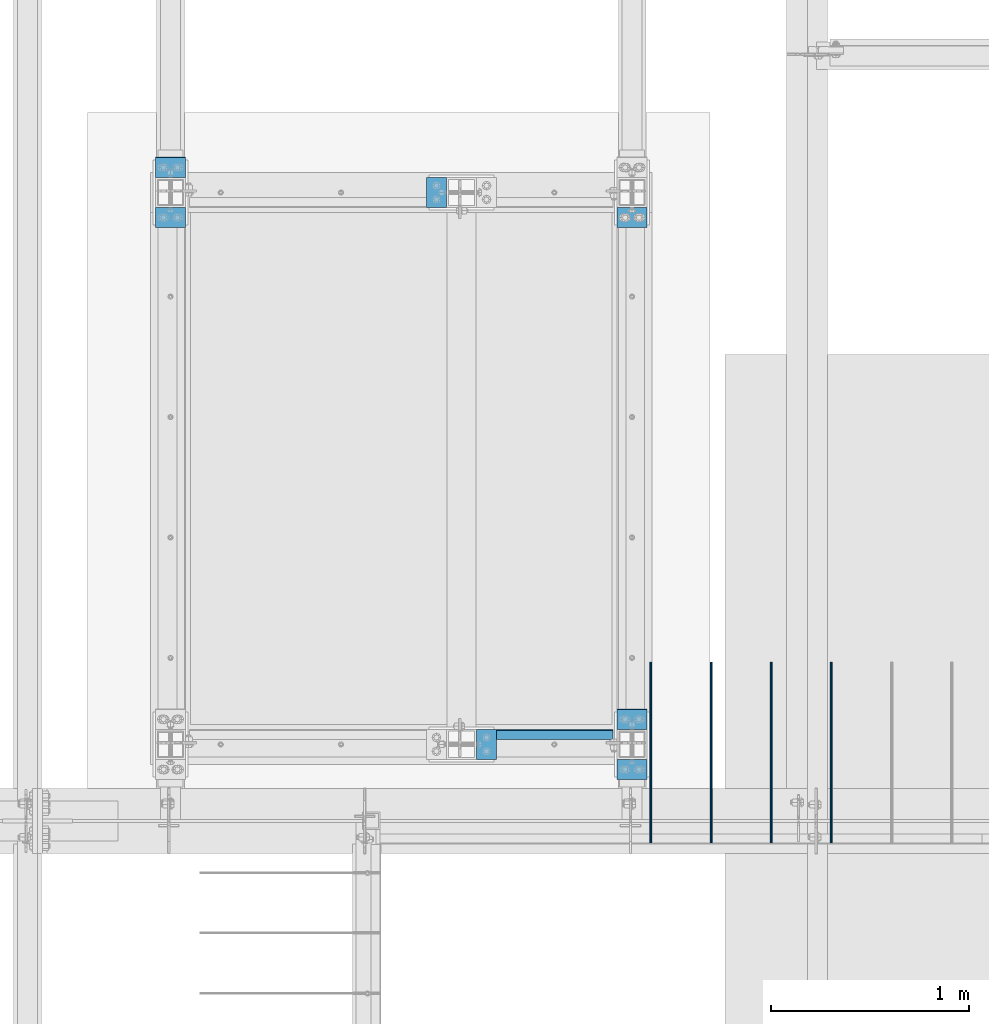
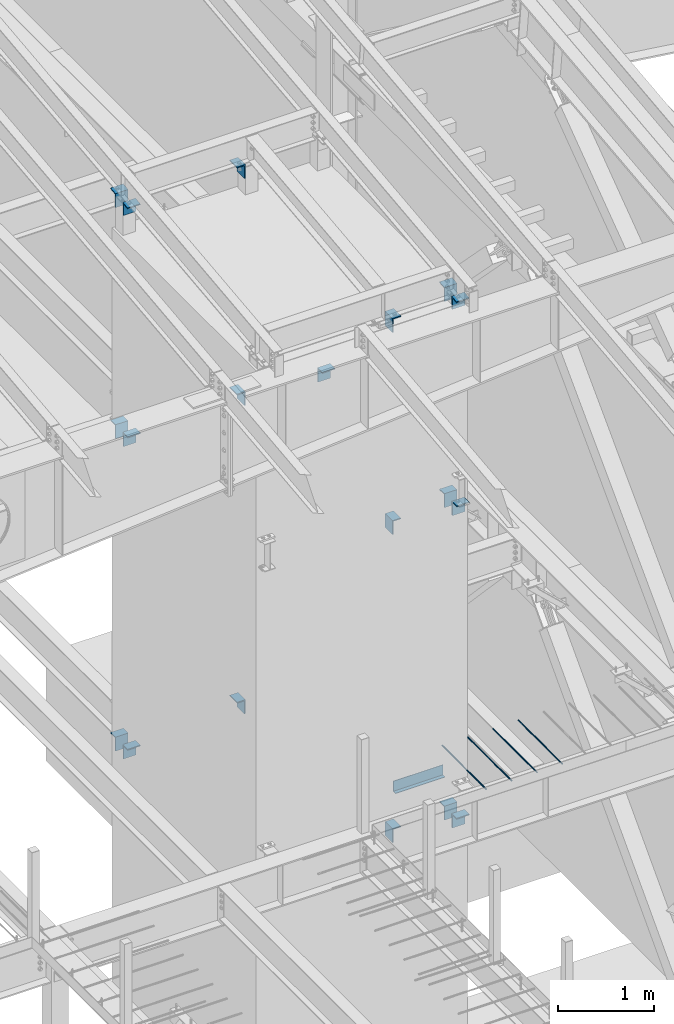
# One storey, part 824 of 1179: 24 beams, 18 elements without a shape of their own.
"""IFC2X3 building model written with IfcOpenShell, lengths in millimetres."""

from ifc_helpers import new_model, si_unit, frame, origin_with_axes, place, context, subcontext, project, spatial, faceted_brep, material, type_object, element, aggregate, save


model = new_model("IFC2X3")

# Units and contexts
model_context = context("Model", 3, precision=1e-05, world=origin_with_axes())
body_context = subcontext(model_context, "Body", "Model", "MODEL_VIEW")
ifc_project = project(units=[si_unit("LENGTHUNIT", "METRE", prefix="MILLI"), si_unit("AREAUNIT", "SQUARE_METRE"), si_unit("VOLUMEUNIT", "CUBIC_METRE"), si_unit("MASSUNIT", "GRAM", prefix="KILO"), si_unit("TIMEUNIT", "SECOND"), si_unit("PLANEANGLEUNIT", "RADIAN"), si_unit("SOLIDANGLEUNIT", "STERADIAN"), si_unit("THERMODYNAMICTEMPERATUREUNIT", "DEGREE_CELSIUS"), si_unit("LUMINOUSINTENSITYUNIT", "LUMEN")], contexts=[model_context])

# Site, building, storey
site_placement = place(None, origin_with_axes())
site = spatial("IfcSite", under=ifc_project, at=site_placement, CompositionType="ELEMENT")
building_placement = place(site_placement, origin_with_axes())
building = spatial("IfcBuilding", under=site, at=building_placement, Name="Undefined", CompositionType="ELEMENT")
storey_placement = place(building_placement, origin_with_axes())
storey = spatial("IfcBuildingStorey", under=building, at=storey_placement, Name="Undefined", CompositionType="ELEMENT", Elevation=0.0)

# Assembly, beam
assembly_1_placement = place(storey_placement, origin_with_axes())
assembly_1 = element("IfcElementAssembly", 1, at=assembly_1_placement, inside=storey, Name="BEAM", AssemblyPlace="NOTDEFINED", PredefinedType="RIGID_FRAME")
ifc_material_1 = material(Name="STEEL/A36")
beam_type_1 = type_object("IfcBeamType", PredefinedType="NOTDEFINED")
beam_1_placement = place(assembly_1_placement, frame((21082.0, 11941.1750007629, 4235.45000610352), z_axis=(1.0, 0.0, 0.0), x_axis=(0.0, 0.0, -1.0)))
beam_1 = element("IfcBeam", 2, at=beam_1_placement, type_object=beam_type_1, material=ifc_material_1, Name="BENT_PLATE", context=body_context, shape_type="Brep", body=[
    faceted_brep([(0.0, -3.17499999999927, -298.450000000001), (0.0, -3.17499999999927, 298.450000000001), (0.0, 3.17499999999927, 298.450000000001), (0.0, 3.17499999999927, -298.450000000001), (133.350006103517, 3.17499999999927, 298.450000000001), (133.350006103517, 3.17499999999927, -298.450000000001), (127.000006103516, -3.17499999999927, -298.450000000001), (127.000006103516, -3.17499999999927, 298.450000000001), (133.350006103517, -47.6250007629387, 298.450000000001), (133.350006103517, -47.6250007629387, -298.450000000001), (127.000006103516, -47.6250007629387, 298.450000000001), (127.000006103516, -47.6250007629387, -298.450000000001)], [[[0, 1, 2, 3]], [[3, 2, 4, 5]], [[1, 0, 6, 7]], [[5, 4, 8, 9]], [[4, 2, 1, 7, 10, 8]], [[7, 6, 11, 10]], [[6, 0, 3, 5, 9, 11]], [[10, 11, 9, 8]]]),
])
aggregate(assembly_1, [beam_1])

# Assembly, beams
assembly_2_placement = place(storey_placement, origin_with_axes())
assembly_2 = element("IfcElementAssembly", 3, at=assembly_2_placement, inside=storey, Name="COLUMN", AssemblyPlace="NOTDEFINED", PredefinedType="RIGID_FRAME")
beam_type_2 = type_object("IfcBeamType", PredefinedType="NOTDEFINED")
beam_2_placement = place(assembly_2_placement, frame((19138.8965677871, 14839.9499984852, 3692.52499649476), z_axis=(1.0, 0.0, 0.0), x_axis=(0.0, -1.0, 0.0)))
beam_2 = element("IfcBeam", 4, at=beam_2_placement, type_object=beam_type_2, material=ifc_material_1, Name="BENT_PLATE", context=body_context, shape_type="Brep", body=[
    faceted_brep([(7.27595761418343e-12, -6.35000000000036, -76.1999999999971), (0.0, -6.35000000000036, 76.2000000000044), (0.0, 6.35000000000036, 76.2000000000044), (-7.27595761418343e-12, 6.35000000000036, -76.1999999999971), (88.8999984741222, 6.34999999999991, 76.2000000000007), (88.8999984741222, 6.34999999999991, -76.2000000000007), (101.599998474123, -6.34999999999991, -76.2000000000007), (101.599998474123, -6.34999999999991, 76.2000000000007), (88.8999984741222, 171.450003051757, 76.2000000000007), (88.8999984741222, 171.450003051757, -76.2000000000007), (101.599998474123, 171.450003051757, 76.2000000000007), (101.599998474123, 171.450003051757, -76.2000000000007)], [[[0, 1, 2, 3]], [[3, 2, 4, 5]], [[1, 0, 6, 7]], [[5, 4, 8, 9]], [[4, 2, 1, 7, 10, 8]], [[7, 6, 11, 10]], [[6, 0, 3, 5, 9, 11]], [[10, 11, 9, 8]]]),
])
beam_3_placement = place(assembly_2_placement, frame((19138.8965677871, 14484.350001537, 3692.52499649476), z_axis=(1.0, 0.0, 0.0), x_axis=(0.0, 1.0, 0.0)))
beam_3 = element("IfcBeam", 5, at=beam_3_placement, type_object=beam_type_2, material=ifc_material_1, Name="BENT_PLATE", context=body_context, shape_type="Brep", body=[
    faceted_brep([(7.27595761418343e-12, -6.35000000000036, -76.1999999999971), (0.0, -6.35000000000036, 76.2000000000044), (0.0, 6.35000000000036, 76.2000000000044), (-7.27595761418343e-12, 6.35000000000036, -76.1999999999971), (101.599998474123, 6.34999999999991, 76.2000000000007), (101.599998474123, 6.34999999999991, -76.2000000000007), (88.8999984741222, -6.34999999999991, -76.2000000000007), (88.8999984741222, -6.34999999999991, 76.2000000000007), (101.599998474123, -171.450003051757, 76.2000000000007), (101.599998474123, -171.450003051757, -76.2000000000007), (88.8999984741222, -171.450003051757, 76.2000000000007), (88.8999984741222, -171.450003051757, -76.2000000000007)], [[[0, 1, 2, 3]], [[3, 2, 4, 5]], [[1, 0, 6, 7]], [[5, 4, 8, 9]], [[4, 2, 1, 7, 10, 8]], [[7, 6, 11, 10]], [[6, 0, 3, 5, 9, 11]], [[10, 11, 9, 8]]]),
])
aggregate(assembly_2, [beam_2, beam_3])

assembly_3_placement = place(storey_placement, origin_with_axes())
assembly_3 = element("IfcElementAssembly", 6, at=assembly_3_placement, inside=storey, Name="COLUMN", AssemblyPlace="NOTDEFINED", PredefinedType="RIGID_FRAME")
beam_4_placement = place(assembly_3_placement, frame((21475.7, 12045.9499984741, 7658.1), z_axis=(1.0, 0.0, 0.0), x_axis=(0.0, -1.0, 0.0)))
beam_4 = element("IfcBeam", 7, at=beam_4_placement, type_object=beam_type_2, material=ifc_material_1, Name="BENT_PLATE", context=body_context, shape_type="Brep", body=[
    faceted_brep([(7.27595761418343e-12, -6.35000000000036, -76.1999999999971), (0.0, -6.35000000000036, 76.2000000000044), (0.0, 6.35000000000036, 76.2000000000044), (-7.27595761418343e-12, 6.35000000000036, -76.1999999999971), (88.8999984741222, 6.34999999999991, 76.2000000000007), (88.8999984741222, 6.34999999999991, -76.2000000000007), (101.599998474123, -6.34999999999991, -76.2000000000007), (101.599998474123, -6.34999999999991, 76.2000000000007), (88.8999984741222, 171.450003051757, 76.2000000000007), (88.8999984741222, 171.450003051757, -76.2000000000007), (101.599998474123, 171.450003051757, 76.2000000000007), (101.599998474123, 171.450003051757, -76.2000000000007)], [[[0, 1, 2, 3]], [[3, 2, 4, 5]], [[1, 0, 6, 7]], [[5, 4, 8, 9]], [[4, 2, 1, 7, 10, 8]], [[7, 6, 11, 10]], [[6, 0, 3, 5, 9, 11]], [[10, 11, 9, 8]]]),
])
beam_5_placement = place(assembly_3_placement, frame((21475.7, 11690.3500015259, 7658.1), z_axis=(1.0, 0.0, 0.0), x_axis=(0.0, 1.0, 0.0)))
beam_5 = element("IfcBeam", 8, at=beam_5_placement, type_object=beam_type_2, material=ifc_material_1, Name="BENT_PLATE", context=body_context, shape_type="Brep", body=[
    faceted_brep([(7.27595761418343e-12, -6.35000000000036, -76.1999999999971), (0.0, -6.35000000000036, 76.2000000000044), (0.0, 6.35000000000036, 76.2000000000044), (-7.27595761418343e-12, 6.35000000000036, -76.1999999999971), (101.599998474123, 6.34999999999991, 76.2000000000007), (101.599998474123, 6.34999999999991, -76.2000000000007), (88.8999984741222, -6.34999999999991, -76.2000000000007), (88.8999984741222, -6.34999999999991, 76.2000000000007), (101.599998474123, -171.450003051757, 76.2000000000007), (101.599998474123, -171.450003051757, -76.2000000000007), (88.8999984741222, -171.450003051757, 76.2000000000007), (88.8999984741222, -171.450003051757, -76.2000000000007)], [[[0, 1, 2, 3]], [[3, 2, 4, 5]], [[1, 0, 6, 7]], [[5, 4, 8, 9]], [[4, 2, 1, 7, 10, 8]], [[7, 6, 11, 10]], [[6, 0, 3, 5, 9, 11]], [[10, 11, 9, 8]]]),
])
aggregate(assembly_3, [beam_4, beam_5])

assembly_4_placement = place(storey_placement, origin_with_axes())
assembly_4 = element("IfcElementAssembly", 9, at=assembly_4_placement, inside=storey, Name="COLUMN", AssemblyPlace="NOTDEFINED", PredefinedType="RIGID_FRAME")
beam_6_placement = place(assembly_4_placement, frame((19138.9, 14839.9499984741, 7658.1), z_axis=(1.0, 0.0, 0.0), x_axis=(0.0, -1.0, 0.0)))
beam_6 = element("IfcBeam", 10, at=beam_6_placement, type_object=beam_type_2, material=ifc_material_1, Name="BENT_PLATE", context=body_context, shape_type="Brep", body=[
    faceted_brep([(7.27595761418343e-12, -6.35000000000036, -76.1999999999971), (0.0, -6.35000000000036, 76.2000000000044), (0.0, 6.35000000000036, 76.2000000000044), (-7.27595761418343e-12, 6.35000000000036, -76.1999999999971), (88.8999984741222, 6.34999999999991, 76.2000000000007), (88.8999984741222, 6.34999999999991, -76.2000000000007), (101.599998474123, -6.34999999999991, -76.2000000000007), (101.599998474123, -6.34999999999991, 76.2000000000007), (88.8999984741222, 171.450003051757, 76.2000000000007), (88.8999984741222, 171.450003051757, -76.2000000000007), (101.599998474123, 171.450003051757, 76.2000000000007), (101.599998474123, 171.450003051757, -76.2000000000007)], [[[0, 1, 2, 3]], [[3, 2, 4, 5]], [[1, 0, 6, 7]], [[5, 4, 8, 9]], [[4, 2, 1, 7, 10, 8]], [[7, 6, 11, 10]], [[6, 0, 3, 5, 9, 11]], [[10, 11, 9, 8]]]),
])
beam_7_placement = place(assembly_4_placement, frame((19138.9, 14484.3500015259, 7658.1), z_axis=(1.0, 0.0, 0.0), x_axis=(0.0, 1.0, 0.0)))
beam_7 = element("IfcBeam", 11, at=beam_7_placement, type_object=beam_type_2, material=ifc_material_1, Name="BENT_PLATE", context=body_context, shape_type="Brep", body=[
    faceted_brep([(7.27595761418343e-12, -6.35000000000036, -76.1999999999971), (0.0, -6.35000000000036, 76.2000000000044), (0.0, 6.35000000000036, 76.2000000000044), (-7.27595761418343e-12, 6.35000000000036, -76.1999999999971), (101.599998474123, 6.34999999999991, 76.2000000000007), (101.599998474123, 6.34999999999991, -76.2000000000007), (88.8999984741222, -6.34999999999991, -76.2000000000007), (88.8999984741222, -6.34999999999991, 76.2000000000007), (101.599998474123, -171.450003051757, 76.2000000000007), (101.599998474123, -171.450003051757, -76.2000000000007), (88.8999984741222, -171.450003051757, 76.2000000000007), (88.8999984741222, -171.450003051757, -76.2000000000007)], [[[0, 1, 2, 3]], [[3, 2, 4, 5]], [[1, 0, 6, 7]], [[5, 4, 8, 9]], [[4, 2, 1, 7, 10, 8]], [[7, 6, 11, 10]], [[6, 0, 3, 5, 9, 11]], [[10, 11, 9, 8]]]),
])
aggregate(assembly_4, [beam_6, beam_7])

# Assembly, beam
assembly_5_placement = place(storey_placement, origin_with_axes())
assembly_5 = element("IfcElementAssembly", 12, at=assembly_5_placement, inside=storey, Name="COLUMN", AssemblyPlace="NOTDEFINED", PredefinedType="RIGID_FRAME")
beam_8_placement = place(assembly_5_placement, frame((21475.7, 14484.3500015259, 7658.1), z_axis=(1.0, 0.0, 0.0), x_axis=(0.0, 1.0, 0.0)))
beam_8 = element("IfcBeam", 13, at=beam_8_placement, type_object=beam_type_2, material=ifc_material_1, Name="BENT_PLATE", context=body_context, shape_type="Brep", body=[
    faceted_brep([(7.27595761418343e-12, -6.35000000000036, -76.1999999999971), (0.0, -6.35000000000036, 76.2000000000044), (0.0, 6.35000000000036, 76.2000000000044), (-7.27595761418343e-12, 6.35000000000036, -76.1999999999971), (101.599998474123, 6.34999999999991, 76.2000000000007), (101.599998474123, 6.34999999999991, -76.2000000000007), (88.8999984741222, -6.34999999999991, -76.2000000000007), (88.8999984741222, -6.34999999999991, 76.2000000000007), (101.599998474123, -171.450003051757, 76.2000000000007), (101.599998474123, -171.450003051757, -76.2000000000007), (88.8999984741222, -171.450003051757, 76.2000000000007), (88.8999984741222, -171.450003051757, -76.2000000000007)], [[[0, 1, 2, 3]], [[3, 2, 4, 5]], [[1, 0, 6, 7]], [[5, 4, 8, 9]], [[4, 2, 1, 7, 10, 8]], [[7, 6, 11, 10]], [[6, 0, 3, 5, 9, 11]], [[10, 11, 9, 8]]]),
])
aggregate(assembly_5, [beam_8])

assembly_6_placement = place(storey_placement, origin_with_axes())
assembly_6 = element("IfcElementAssembly", 14, at=assembly_6_placement, inside=storey, Name="COLUMN", AssemblyPlace="NOTDEFINED", PredefinedType="RIGID_FRAME")
beam_9_placement = place(assembly_6_placement, frame((20789.8999984741, 11868.15, 7658.1), z_axis=(0.0, 1.0, 0.0), x_axis=(-1.0, 0.0, 0.0)))
beam_9 = element("IfcBeam", 15, at=beam_9_placement, type_object=beam_type_2, material=ifc_material_1, Name="BENT_PLATE", context=body_context, shape_type="Brep", body=[
    faceted_brep([(7.27595761418343e-12, -6.35000000000036, -76.1999999999971), (0.0, -6.35000000000036, 76.2000000000044), (0.0, 6.35000000000036, 76.2000000000044), (-7.27595761418343e-12, 6.35000000000036, -76.1999999999971), (101.599998474123, 6.34999999999991, 76.2000000000007), (101.599998474123, 6.34999999999991, -76.2000000000007), (88.8999984741222, -6.34999999999991, -76.2000000000007), (88.8999984741222, -6.34999999999991, 76.2000000000007), (101.599998474123, -171.450003051757, 76.2000000000007), (101.599998474123, -171.450003051757, -76.2000000000007), (88.8999984741222, -171.450003051757, 76.2000000000007), (88.8999984741222, -171.450003051757, -76.2000000000007)], [[[0, 1, 2, 3]], [[3, 2, 4, 5]], [[1, 0, 6, 7]], [[5, 4, 8, 9]], [[4, 2, 1, 7, 10, 8]], [[7, 6, 11, 10]], [[6, 0, 3, 5, 9, 11]], [[10, 11, 9, 8]]]),
])
aggregate(assembly_6, [beam_9])

assembly_7_placement = place(storey_placement, origin_with_axes())
assembly_7 = element("IfcElementAssembly", 16, at=assembly_7_placement, inside=storey, Name="COLUMN", AssemblyPlace="NOTDEFINED", PredefinedType="RIGID_FRAME")
beam_10_placement = place(assembly_7_placement, frame((20434.3000015259, 14662.15, 7658.1), z_axis=(0.0, 1.0, 0.0), x_axis=(1.0, 0.0, 0.0)))
beam_10 = element("IfcBeam", 17, at=beam_10_placement, type_object=beam_type_2, material=ifc_material_1, Name="BENT_PLATE", context=body_context, shape_type="Brep", body=[
    faceted_brep([(7.27595761418343e-12, -6.35000000000036, -76.1999999999971), (0.0, -6.35000000000036, 76.2000000000044), (0.0, 6.35000000000036, 76.2000000000044), (-7.27595761418343e-12, 6.35000000000036, -76.1999999999971), (88.8999984741222, 6.34999999999991, 76.2000000000007), (88.8999984741222, 6.34999999999991, -76.2000000000007), (101.599998474123, -6.34999999999991, -76.2000000000007), (101.599998474123, -6.34999999999991, 76.2000000000007), (88.8999984741222, 171.450003051757, 76.2000000000007), (88.8999984741222, 171.450003051757, -76.2000000000007), (101.599998474123, 171.450003051757, 76.2000000000007), (101.599998474123, 171.450003051757, -76.2000000000007)], [[[0, 1, 2, 3]], [[3, 2, 4, 5]], [[1, 0, 6, 7]], [[5, 4, 8, 9]], [[4, 2, 1, 7, 10, 8]], [[7, 6, 11, 10]], [[6, 0, 3, 5, 9, 11]], [[10, 11, 9, 8]]]),
])
aggregate(assembly_7, [beam_10])

# Assembly, beams
assembly_8_placement = place(storey_placement, origin_with_axes())
assembly_8 = element("IfcElementAssembly", 18, at=assembly_8_placement, inside=storey, Name="COLUMN", AssemblyPlace="NOTDEFINED", PredefinedType="RIGID_FRAME")
beam_11_placement = place(assembly_8_placement, frame((21475.7, 12046.6686266753, 10288.708863098), z_axis=(1.0, 0.0, 0.0), x_axis=(2.37931089941412e-10, -0.993575662698832, -0.113169794965695)))
beam_11 = element("IfcBeam", 19, at=beam_11_placement, type_object=beam_type_2, material=ifc_material_1, Name="BENT_PLATE", context=body_context, shape_type="Brep", body=[
    faceted_brep([(7.27595761418343e-12, -6.35000000000036, -76.1999999999971), (0.0, -6.35000000000036, 76.2000000000044), (0.0, 6.35000000000036, 76.2000000000044), (-7.27595761418343e-12, 6.35000000000036, -76.1999999999971), (90.9468588647287, 6.35000004562426, 76.2000000000007), (90.9468588647287, 6.35000004562426, -76.2000000000007), (102.284159680639, -6.34999994868303, -76.2000000000007), (102.284159680639, -6.34999994868303, 76.2000000000007), (109.787335175104, 171.984030604186, 76.2000000000007), (109.787335175104, 171.984030604186, -76.2000000000007), (122.405964338148, 170.548691604019, 76.2000000000007), (122.405964338148, 170.548691604019, -76.2000000000007)], [[[0, 1, 2, 3]], [[3, 2, 4, 5]], [[1, 0, 6, 7]], [[5, 4, 8, 9]], [[4, 2, 1, 7, 10, 8]], [[7, 6, 11, 10]], [[6, 0, 3, 5, 9, 11]], [[10, 11, 9, 8]]]),
])
beam_12_placement = place(assembly_8_placement, frame((21475.7, 11691.7055089898, 10248.5067435805), z_axis=(1.0, 0.0, 0.0), x_axis=(0.0, 0.993676146336441, 0.112284087038017)))
beam_12 = element("IfcBeam", 20, at=beam_12_placement, type_object=beam_type_2, material=ifc_material_1, Name="BENT_PLATE", context=body_context, shape_type="Brep", body=[
    faceted_brep([(7.27595761418343e-12, -6.35000000000036, -76.1999999999971), (0.0, -6.35000000000036, 76.2000000000044), (0.0, 6.35000000000036, 76.2000000000044), (-7.27595761418343e-12, 6.35000000000036, -76.1999999999971), (101.599998474123, 6.34999999999991, 76.2000000000007), (101.599998474123, 6.34999999999991, -76.2000000000007), (87.3840912620235, -6.35000000880973, -76.2000000000007), (87.3840912620235, -6.35000000880973, 76.2000000000007), (83.5423060723097, -153.454462787842, 76.2000000000007), (83.5423060723097, -153.454462787842, -76.2000000000007), (70.9226190138452, -152.02845488246, 76.2000000000007), (70.9226190138452, -152.02845488246, -76.2000000000007)], [[[0, 1, 2, 3]], [[3, 2, 4, 5]], [[1, 0, 6, 7]], [[5, 4, 8, 9]], [[4, 2, 1, 7, 10, 8]], [[7, 6, 11, 10]], [[6, 0, 3, 5, 9, 11]], [[10, 11, 9, 8]]]),
])
aggregate(assembly_8, [beam_11, beam_12])

assembly_9_placement = place(storey_placement, origin_with_axes())
assembly_9 = element("IfcElementAssembly", 21, at=assembly_9_placement, inside=storey, Name="COLUMN", AssemblyPlace="NOTDEFINED", PredefinedType="RIGID_FRAME")
beam_13_placement = place(assembly_9_placement, frame((19138.9, 14840.6686266753, 10604.4271585818), z_axis=(1.0, 0.0, 0.0), x_axis=(2.37931089941412e-10, -0.993575662698832, -0.113169794965695)))
beam_13 = element("IfcBeam", 22, at=beam_13_placement, type_object=beam_type_2, material=ifc_material_1, Name="BENT_PLATE", context=body_context, shape_type="Brep", body=[
    faceted_brep([(7.27595761418343e-12, -6.35000000000036, -76.1999999999971), (0.0, -6.35000000000036, 76.2000000000044), (0.0, 6.35000000000036, 76.2000000000044), (-7.27595761418343e-12, 6.35000000000036, -76.1999999999971), (90.9468588647287, 6.35000004562426, 76.2000000000007), (90.9468588647287, 6.35000004562426, -76.2000000000007), (102.284159680639, -6.34999994868303, -76.2000000000007), (102.284159680639, -6.34999994868303, 76.2000000000007), (109.787335175104, 171.984030604186, 76.2000000000007), (109.787335175104, 171.984030604186, -76.2000000000007), (122.405964338148, 170.548691604019, 76.2000000000007), (122.405964338148, 170.548691604019, -76.2000000000007)], [[[0, 1, 2, 3]], [[3, 2, 4, 5]], [[1, 0, 6, 7]], [[5, 4, 8, 9]], [[4, 2, 1, 7, 10, 8]], [[7, 6, 11, 10]], [[6, 0, 3, 5, 9, 11]], [[10, 11, 9, 8]]]),
])
beam_14_placement = place(assembly_9_placement, frame((19138.9, 14485.7055089898, 10564.2250390642), z_axis=(1.0, 0.0, 0.0), x_axis=(0.0, 0.993676146336441, 0.112284087038017)))
beam_14 = element("IfcBeam", 23, at=beam_14_placement, type_object=beam_type_2, material=ifc_material_1, Name="BENT_PLATE", context=body_context, shape_type="Brep", body=[
    faceted_brep([(7.27595761418343e-12, -6.35000000000036, -76.1999999999971), (0.0, -6.35000000000036, 76.2000000000044), (0.0, 6.35000000000036, 76.2000000000044), (-7.27595761418343e-12, 6.35000000000036, -76.1999999999971), (101.599998474123, 6.34999999999991, 76.2000000000007), (101.599998474123, 6.34999999999991, -76.2000000000007), (87.3840912620235, -6.35000000880973, -76.2000000000007), (87.3840912620235, -6.35000000880973, 76.2000000000007), (83.5423060723097, -153.454462787842, 76.2000000000007), (83.5423060723097, -153.454462787842, -76.2000000000007), (70.9226190138452, -152.02845488246, 76.2000000000007), (70.9226190138452, -152.02845488246, -76.2000000000007)], [[[0, 1, 2, 3]], [[3, 2, 4, 5]], [[1, 0, 6, 7]], [[5, 4, 8, 9]], [[4, 2, 1, 7, 10, 8]], [[7, 6, 11, 10]], [[6, 0, 3, 5, 9, 11]], [[10, 11, 9, 8]]]),
])
aggregate(assembly_9, [beam_13, beam_14])

# Assembly, beam
assembly_10_placement = place(storey_placement, origin_with_axes())
assembly_10 = element("IfcElementAssembly", 24, at=assembly_10_placement, inside=storey, Name="COLUMN", AssemblyPlace="NOTDEFINED", PredefinedType="RIGID_FRAME")
beam_15_placement = place(assembly_10_placement, frame((20789.8999984741, 11868.15, 10225.285937), z_axis=(0.0, 1.0, 0.0), x_axis=(-1.0, 0.0, 0.0)))
beam_15 = element("IfcBeam", 25, at=beam_15_placement, type_object=beam_type_2, material=ifc_material_1, Name="BENT_PLATE", context=body_context, shape_type="Brep", body=[
    faceted_brep([(7.27595761418343e-12, -6.35000000000036, -76.1999999999971), (0.0, -6.35000000000036, 76.2000000000044), (0.0, 6.35000000000036, 76.2000000000044), (-7.27595761418343e-12, 6.35000000000036, -76.1999999999971), (101.599998474123, 6.34999999999991, 76.2000000000007), (101.599998474123, 6.34999999999991, -76.2000000000007), (88.8999984741222, -6.34999999999991, -76.2000000000007), (88.8999984741222, -6.34999999999991, 76.2000000000007), (101.599998474123, -171.450003051757, 76.2000000000007), (101.599998474123, -171.450003051757, -76.2000000000007), (88.8999984741222, -171.450003051757, 76.2000000000007), (88.8999984741222, -171.450003051757, -76.2000000000007)], [[[0, 1, 2, 3]], [[3, 2, 4, 5]], [[1, 0, 6, 7]], [[5, 4, 8, 9]], [[4, 2, 1, 7, 10, 8]], [[7, 6, 11, 10]], [[6, 0, 3, 5, 9, 11]], [[10, 11, 9, 8]]]),
])
aggregate(assembly_10, [beam_15])

assembly_11_placement = place(storey_placement, origin_with_axes())
assembly_11 = element("IfcElementAssembly", 26, at=assembly_11_placement, inside=storey, Name="COLUMN", AssemblyPlace="NOTDEFINED", PredefinedType="RIGID_FRAME")
beam_16_placement = place(assembly_11_placement, frame((20434.3000015259, 14662.15, 10540.9082183146), z_axis=(0.0, 1.0, 0.0), x_axis=(1.0, 0.0, 0.0)))
beam_16 = element("IfcBeam", 27, at=beam_16_placement, type_object=beam_type_2, material=ifc_material_1, Name="BENT_PLATE", context=body_context, shape_type="Brep", body=[
    faceted_brep([(7.27595761418343e-12, -6.35000000000036, -76.1999999999971), (0.0, -6.35000000000036, 76.2000000000044), (0.0, 6.35000000000036, 76.2000000000044), (-7.27595761418343e-12, 6.35000000000036, -76.1999999999971), (88.8999984741222, 6.34999999999991, 76.2000000000007), (88.8999984741222, 6.34999999999991, -76.2000000000007), (101.599998474123, -6.34999999999991, -76.2000000000007), (101.599998474123, -6.34999999999991, 76.2000000000007), (88.8999984741222, 171.450003051757, 76.2000000000007), (88.8999984741222, 171.450003051757, -76.2000000000007), (101.599998474123, 171.450003051757, 76.2000000000007), (101.599998474123, 171.450003051757, -76.2000000000007)], [[[0, 1, 2, 3]], [[3, 2, 4, 5]], [[1, 0, 6, 7]], [[5, 4, 8, 9]], [[4, 2, 1, 7, 10, 8]], [[7, 6, 11, 10]], [[6, 0, 3, 5, 9, 11]], [[10, 11, 9, 8]]]),
])
aggregate(assembly_11, [beam_16])

assembly_12_placement = place(storey_placement, origin_with_axes())
assembly_12 = element("IfcElementAssembly", 28, at=assembly_12_placement, inside=storey, Name="COLUMN", AssemblyPlace="NOTDEFINED", PredefinedType="RIGID_FRAME")
beam_17_placement = place(assembly_12_placement, frame((20789.8999984741, 11868.15, 3746.49999998571), z_axis=(0.0, 1.0, 0.0), x_axis=(-1.0, 0.0, 0.0)))
beam_17 = element("IfcBeam", 29, at=beam_17_placement, type_object=beam_type_2, material=ifc_material_1, Name="BENT_PLATE", context=body_context, shape_type="Brep", body=[
    faceted_brep([(7.27595761418343e-12, -6.35000000000036, -76.1999999999971), (0.0, -6.35000000000036, 76.2000000000044), (0.0, 6.35000000000036, 76.2000000000044), (-7.27595761418343e-12, 6.35000000000036, -76.1999999999971), (101.599998474123, 6.34999999999991, 76.2000000000007), (101.599998474123, 6.34999999999991, -76.2000000000007), (88.8999984741222, -6.34999999999991, -76.2000000000007), (88.8999984741222, -6.34999999999991, 76.2000000000007), (101.599998474123, -171.450003051757, 76.2000000000007), (101.599998474123, -171.450003051757, -76.2000000000007), (88.8999984741222, -171.450003051757, 76.2000000000007), (88.8999984741222, -171.450003051757, -76.2000000000007)], [[[0, 1, 2, 3]], [[3, 2, 4, 5]], [[1, 0, 6, 7]], [[5, 4, 8, 9]], [[4, 2, 1, 7, 10, 8]], [[7, 6, 11, 10]], [[6, 0, 3, 5, 9, 11]], [[10, 11, 9, 8]]]),
])
aggregate(assembly_12, [beam_17])

assembly_13_placement = place(storey_placement, origin_with_axes())
assembly_13 = element("IfcElementAssembly", 30, at=assembly_13_placement, inside=storey, Name="COLUMN", AssemblyPlace="NOTDEFINED", PredefinedType="RIGID_FRAME")
beam_18_placement = place(assembly_13_placement, frame((20434.3000015259, 14662.15, 3746.5), z_axis=(0.0, 1.0, 0.0), x_axis=(1.0, 0.0, 0.0)))
beam_18 = element("IfcBeam", 31, at=beam_18_placement, type_object=beam_type_2, material=ifc_material_1, Name="BENT_PLATE", context=body_context, shape_type="Brep", body=[
    faceted_brep([(7.27595761418343e-12, -6.35000000000036, -76.1999999999971), (0.0, -6.35000000000036, 76.2000000000044), (0.0, 6.35000000000036, 76.2000000000044), (-7.27595761418343e-12, 6.35000000000036, -76.1999999999971), (88.8999984741222, 6.34999999999991, 76.2000000000007), (88.8999984741222, 6.34999999999991, -76.2000000000007), (101.599998474123, -6.34999999999991, -76.2000000000007), (101.599998474123, -6.34999999999991, 76.2000000000007), (88.8999984741222, 171.450003051757, 76.2000000000007), (88.8999984741222, 171.450003051757, -76.2000000000007), (101.599998474123, 171.450003051757, 76.2000000000007), (101.599998474123, 171.450003051757, -76.2000000000007)], [[[0, 1, 2, 3]], [[3, 2, 4, 5]], [[1, 0, 6, 7]], [[5, 4, 8, 9]], [[4, 2, 1, 7, 10, 8]], [[7, 6, 11, 10]], [[6, 0, 3, 5, 9, 11]], [[10, 11, 9, 8]]]),
])
aggregate(assembly_13, [beam_18])

# Assembly, beams
assembly_14_placement = place(storey_placement, origin_with_axes())
assembly_14 = element("IfcElementAssembly", 32, at=assembly_14_placement, inside=storey, Name="COLUMN", AssemblyPlace="NOTDEFINED", PredefinedType="RIGID_FRAME")
beam_19_placement = place(assembly_14_placement, frame((21475.6998279452, 12045.9499984741, 3692.52499649481), z_axis=(1.0, 0.0, 0.0), x_axis=(0.0, -1.0, 0.0)))
beam_19 = element("IfcBeam", 33, at=beam_19_placement, type_object=beam_type_2, material=ifc_material_1, Name="BENT_PLATE", context=body_context, shape_type="Brep", body=[
    faceted_brep([(7.27595761418343e-12, -6.35000000000036, -76.1999999999971), (0.0, -6.35000000000036, 76.2000000000044), (0.0, 6.35000000000036, 76.2000000000044), (-7.27595761418343e-12, 6.35000000000036, -76.1999999999971), (88.8999984741222, 6.34999999999991, 76.2000000000007), (88.8999984741222, 6.34999999999991, -76.2000000000007), (101.599998474123, -6.34999999999991, -76.2000000000007), (101.599998474123, -6.34999999999991, 76.2000000000007), (88.8999984741222, 171.450003051757, 76.2000000000007), (88.8999984741222, 171.450003051757, -76.2000000000007), (101.599998474123, 171.450003051757, 76.2000000000007), (101.599998474123, 171.450003051757, -76.2000000000007)], [[[0, 1, 2, 3]], [[3, 2, 4, 5]], [[1, 0, 6, 7]], [[5, 4, 8, 9]], [[4, 2, 1, 7, 10, 8]], [[7, 6, 11, 10]], [[6, 0, 3, 5, 9, 11]], [[10, 11, 9, 8]]]),
])
beam_20_placement = place(assembly_14_placement, frame((21475.6998284746, 11690.3500015259, 3692.52499649481), z_axis=(1.0, 0.0, 0.0), x_axis=(0.0, 1.0, 0.0)))
beam_20 = element("IfcBeam", 34, at=beam_20_placement, type_object=beam_type_2, material=ifc_material_1, Name="BENT_PLATE", context=body_context, shape_type="Brep", body=[
    faceted_brep([(7.27595761418343e-12, -6.35000000000036, -76.1999999999971), (0.0, -6.35000000000036, 76.2000000000044), (0.0, 6.35000000000036, 76.2000000000044), (-7.27595761418343e-12, 6.35000000000036, -76.1999999999971), (101.599998474123, 6.34999999999991, 76.2000000000007), (101.599998474123, 6.34999999999991, -76.2000000000007), (88.8999984741222, -6.34999999999991, -76.2000000000007), (88.8999984741222, -6.34999999999991, 76.2000000000007), (101.599998474123, -171.450003051757, 76.2000000000007), (101.599998474123, -171.450003051757, -76.2000000000007), (88.8999984741222, -171.450003051757, 76.2000000000007), (88.8999984741222, -171.450003051757, -76.2000000000007)], [[[0, 1, 2, 3]], [[3, 2, 4, 5]], [[1, 0, 6, 7]], [[5, 4, 8, 9]], [[4, 2, 1, 7, 10, 8]], [[7, 6, 11, 10]], [[6, 0, 3, 5, 9, 11]], [[10, 11, 9, 8]]]),
])
aggregate(assembly_14, [beam_19, beam_20])

# Assembly, beam
assembly_15_placement = place(storey_placement, origin_with_axes())
assembly_15 = element("IfcElementAssembly", 35, at=assembly_15_placement, inside=storey, Name="#4 DOWEL", AssemblyPlace="NOTDEFINED", PredefinedType="NOTDEFINED")
ifc_material_2 = material(Name="REBAR/A615-40")
beam_type_3 = type_object("IfcBeamType", Name="#4 DOWEL", PredefinedType="NOTDEFINED")
beam_21_placement = place(assembly_15_placement, frame((22485.35, 11369.675, 4203.70000610352), z_axis=(0.0, 0.0, 1.0), x_axis=(0.0, 1.0, 0.0)))
beam_21 = element("IfcBeam", 36, at=beam_21_placement, type_object=beam_type_3, material=ifc_material_2, Name="#4 DOWEL", ObjectType="#4 DOWEL", context=body_context, shape_type="Brep", body=[
    faceted_brep([(0.0, -6.34999999999854, 0.0), (0.0, -4.49012806053361, -4.49012806053452), (914.399999999994, -4.49012806053452, -4.49012806042992), (914.399999999994, -6.34999999999991, 1.0550138540566e-10), (0.0, 0.0, -6.34999999999991), (914.399999999994, 0.0, -6.34999999989668), (0.0, 4.49012806053361, -4.49012806053452), (914.399999999994, 4.49012806053452, -4.49012806042992), (0.0, 6.34999999999854, 0.0), (914.399999999994, 6.34999999999991, 1.0550138540566e-10), (0.0, 4.49012806053361, 4.49012806053452), (914.399999999995, 4.49012806053452, 4.49012806064184), (0.0, 0.0, 6.34999999999991), (914.399999999995, 0.0, 6.35000000010768), (0.0, -4.49012806053361, 4.49012806053452), (914.399999999995, -4.49012806053452, 4.49012806064184)], [[[0, 1, 2, 3]], [[1, 4, 5, 2]], [[4, 6, 7, 5]], [[6, 8, 9, 7]], [[8, 10, 11, 9]], [[10, 12, 13, 11]], [[12, 14, 15, 13]], [[14, 0, 3, 15]], [[5, 7, 9, 11, 13, 15, 3, 2]], [[14, 12, 10, 8, 6, 4, 1, 0]]]),
])
aggregate(assembly_15, [beam_21])

assembly_16_placement = place(storey_placement, origin_with_axes())
assembly_16 = element("IfcElementAssembly", 37, at=assembly_16_placement, inside=storey, Name="#4 DOWEL", AssemblyPlace="NOTDEFINED", PredefinedType="NOTDEFINED")
beam_22_placement = place(assembly_16_placement, frame((22180.55, 11369.675, 4203.70000610352), z_axis=(0.0, 0.0, 1.0), x_axis=(0.0, 1.0, 0.0)))
beam_22 = element("IfcBeam", 38, at=beam_22_placement, type_object=beam_type_3, material=ifc_material_2, Name="#4 DOWEL", ObjectType="#4 DOWEL", context=body_context, shape_type="Brep", body=[
    faceted_brep([(0.0, -6.34999999999854, 0.0), (0.0, -4.49012806053361, -4.49012806053452), (914.399999999994, -4.49012806053452, -4.49012806042992), (914.399999999994, -6.34999999999991, 1.0550138540566e-10), (0.0, 0.0, -6.34999999999991), (914.399999999994, 0.0, -6.34999999989668), (0.0, 4.49012806053361, -4.49012806053452), (914.399999999994, 4.49012806053452, -4.49012806042992), (0.0, 6.34999999999854, 0.0), (914.399999999994, 6.34999999999991, 1.0550138540566e-10), (0.0, 4.49012806053361, 4.49012806053452), (914.399999999995, 4.49012806053452, 4.49012806064184), (0.0, 0.0, 6.34999999999991), (914.399999999995, 0.0, 6.35000000010768), (0.0, -4.49012806053361, 4.49012806053452), (914.399999999995, -4.49012806053452, 4.49012806064184)], [[[0, 1, 2, 3]], [[1, 4, 5, 2]], [[4, 6, 7, 5]], [[6, 8, 9, 7]], [[8, 10, 11, 9]], [[10, 12, 13, 11]], [[12, 14, 15, 13]], [[14, 0, 3, 15]], [[5, 7, 9, 11, 13, 15, 3, 2]], [[14, 12, 10, 8, 6, 4, 1, 0]]]),
])
aggregate(assembly_16, [beam_22])

assembly_17_placement = place(storey_placement, origin_with_axes())
assembly_17 = element("IfcElementAssembly", 39, at=assembly_17_placement, inside=storey, Name="#4 DOWEL", AssemblyPlace="NOTDEFINED", PredefinedType="NOTDEFINED")
beam_23_placement = place(assembly_17_placement, frame((21875.75, 11369.675, 4203.70000610352), z_axis=(0.0, 0.0, 1.0), x_axis=(0.0, 1.0, 0.0)))
beam_23 = element("IfcBeam", 40, at=beam_23_placement, type_object=beam_type_3, material=ifc_material_2, Name="#4 DOWEL", ObjectType="#4 DOWEL", context=body_context, shape_type="Brep", body=[
    faceted_brep([(0.0, -6.34999999999854, 0.0), (0.0, -4.49012806053361, -4.49012806053452), (914.399999999994, -4.49012806053452, -4.49012806042992), (914.399999999994, -6.34999999999991, 1.0550138540566e-10), (0.0, 0.0, -6.34999999999991), (914.399999999994, 0.0, -6.34999999989668), (0.0, 4.49012806053361, -4.49012806053452), (914.399999999994, 4.49012806053452, -4.49012806042992), (0.0, 6.34999999999854, 0.0), (914.399999999994, 6.34999999999991, 1.0550138540566e-10), (0.0, 4.49012806053361, 4.49012806053452), (914.399999999995, 4.49012806053452, 4.49012806064184), (0.0, 0.0, 6.34999999999991), (914.399999999995, 0.0, 6.35000000010768), (0.0, -4.49012806053361, 4.49012806053452), (914.399999999995, -4.49012806053452, 4.49012806064184)], [[[0, 1, 2, 3]], [[1, 4, 5, 2]], [[4, 6, 7, 5]], [[6, 8, 9, 7]], [[8, 10, 11, 9]], [[10, 12, 13, 11]], [[12, 14, 15, 13]], [[14, 0, 3, 15]], [[5, 7, 9, 11, 13, 15, 3, 2]], [[14, 12, 10, 8, 6, 4, 1, 0]]]),
])
aggregate(assembly_17, [beam_23])

assembly_18_placement = place(storey_placement, origin_with_axes())
assembly_18 = element("IfcElementAssembly", 41, at=assembly_18_placement, inside=storey, Name="#4 DOWEL", AssemblyPlace="NOTDEFINED", PredefinedType="NOTDEFINED")
beam_24_placement = place(assembly_18_placement, frame((21570.95, 11369.675, 4203.70000610352), z_axis=(0.0, 0.0, 1.0), x_axis=(0.0, 1.0, 0.0)))
beam_24 = element("IfcBeam", 42, at=beam_24_placement, type_object=beam_type_3, material=ifc_material_2, Name="#4 DOWEL", ObjectType="#4 DOWEL", context=body_context, shape_type="Brep", body=[
    faceted_brep([(0.0, -6.34999999999854, 0.0), (0.0, -4.49012806053361, -4.49012806053452), (914.399999999994, -4.49012806053452, -4.49012806042992), (914.399999999994, -6.34999999999991, 1.0550138540566e-10), (0.0, 0.0, -6.34999999999991), (914.399999999994, 0.0, -6.34999999989668), (0.0, 4.49012806053361, -4.49012806053452), (914.399999999994, 4.49012806053452, -4.49012806042992), (0.0, 6.34999999999854, 0.0), (914.399999999994, 6.34999999999991, 1.0550138540566e-10), (0.0, 4.49012806053361, 4.49012806053452), (914.399999999995, 4.49012806053452, 4.49012806064184), (0.0, 0.0, 6.34999999999991), (914.399999999995, 0.0, 6.35000000010768), (0.0, -4.49012806053361, 4.49012806053452), (914.399999999995, -4.49012806053452, 4.49012806064184)], [[[0, 1, 2, 3]], [[1, 4, 5, 2]], [[4, 6, 7, 5]], [[6, 8, 9, 7]], [[8, 10, 11, 9]], [[10, 12, 13, 11]], [[12, 14, 15, 13]], [[14, 0, 3, 15]], [[5, 7, 9, 11, 13, 15, 3, 2]], [[14, 12, 10, 8, 6, 4, 1, 0]]]),
])
aggregate(assembly_18, [beam_24])

save(model, "model.ifc")
